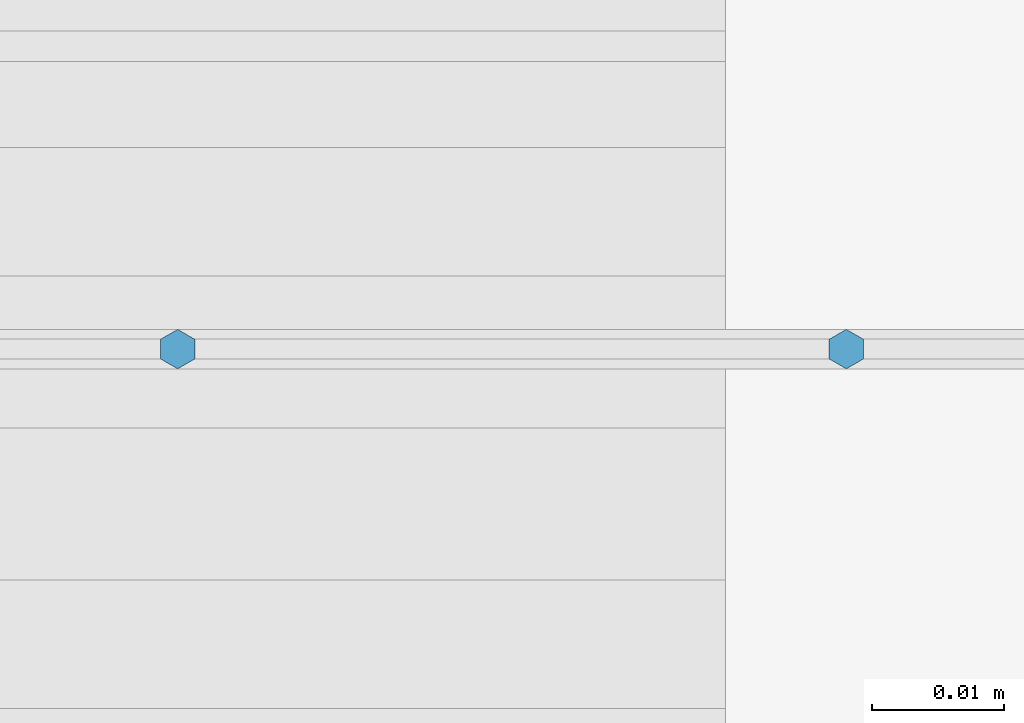
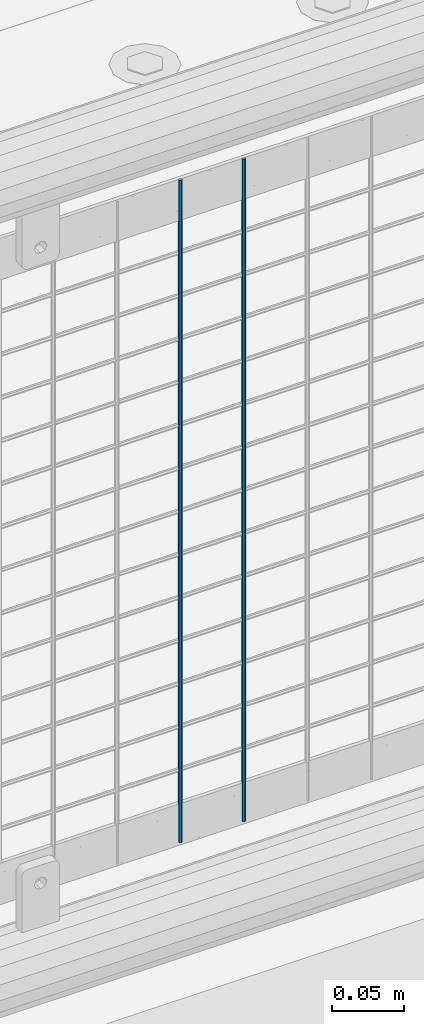
# One storey, part 83 of 242: 2 columns.
"""IFC2X3 building model written with IfcOpenShell, lengths in millimetres."""

from ifc_helpers import new_model, si_unit, frame, origin_with_axes, place, context, subcontext, project, spatial, faceted_brep, material, type_object, element, save


model = new_model("IFC2X3")

# Units and contexts
model_context = context("Model", 3, precision=1e-05, world=origin_with_axes())
body_context = subcontext(model_context, "Body", "Model", "MODEL_VIEW")
ifc_project = project(units=[si_unit("LENGTHUNIT", "METRE", prefix="MILLI"), si_unit("AREAUNIT", "SQUARE_METRE"), si_unit("VOLUMEUNIT", "CUBIC_METRE"), si_unit("MASSUNIT", "GRAM", prefix="KILO"), si_unit("TIMEUNIT", "SECOND"), si_unit("PLANEANGLEUNIT", "RADIAN"), si_unit("SOLIDANGLEUNIT", "STERADIAN"), si_unit("THERMODYNAMICTEMPERATUREUNIT", "DEGREE_CELSIUS"), si_unit("LUMINOUSINTENSITYUNIT", "LUMEN")], contexts=[model_context])

# Site, building, storey
site_placement = place(None, origin_with_axes())
site = spatial("IfcSite", under=ifc_project, at=site_placement, CompositionType="ELEMENT")
building_placement = place(site_placement, origin_with_axes())
building = spatial("IfcBuilding", under=site, at=building_placement, Name="Standard", CompositionType="ELEMENT")
storey_placement = place(building_placement, origin_with_axes())
storey = spatial("IfcBuildingStorey", under=building, at=storey_placement, Name="Undefined", CompositionType="ELEMENT", Elevation=0.0)

# Columns
ifc_material = material(Name="Misc_Undefined")
column_type = type_object("IfcColumnType", Name="D3", PredefinedType="NOTDEFINED")
for number, where, z_axis, x_axis in (
    (1, (-33380.828, -19329.5, 353.02), (-1.0, 0.0, 0.0), (0.0, 0.0, 1.0)),
    (2, (-33431.621, -19329.5, 353.02), (-1.0, 0.0, 0.0), (0.0, 0.0, 1.0)),
):
    element("IfcColumn", number, at=place(storey_placement, frame(where, z_axis=z_axis, x_axis=x_axis)), inside=storey, type_object=column_type, material=ifc_material, ObjectType="D3", context=body_context, shape_type="Brep", body=[
        faceted_brep([(0.0, -1.50000000000364, 0.0), (-3.63797880709171e-12, -0.750000000003638, -1.29903810567669), (560.0, -0.75, -1.29903810567703), (560.0, -1.5, 0.0), (0.0, 0.749999999996362, -1.29903810567669), (560.0, 0.75, -1.29903810567703), (-3.63797880709171e-12, 1.49999999999636, 0.0), (560.0, 1.5, 0.0), (0.0, 0.749999999996362, 1.29903810567669), (560.0, 0.75, 1.29903810567703), (-3.63797880709171e-12, -0.750000000003638, 1.29903810567669), (560.0, -0.75, 1.29903810567703)], [[[0, 1, 2, 3]], [[1, 4, 5, 2]], [[4, 6, 7, 5]], [[6, 8, 9, 7]], [[8, 10, 11, 9]], [[10, 0, 3, 11]], [[5, 7, 9, 11, 3, 2]], [[10, 8, 6, 4, 1, 0]]]),
    ])

save(model, "model.ifc")
